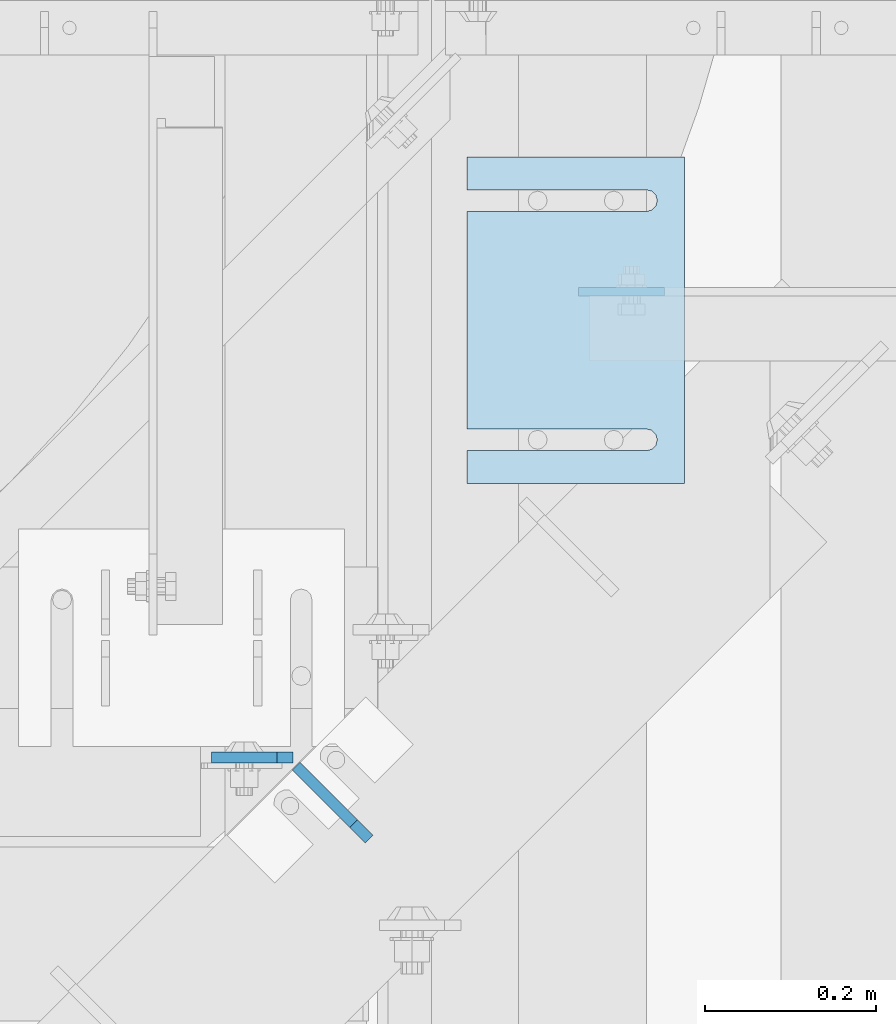
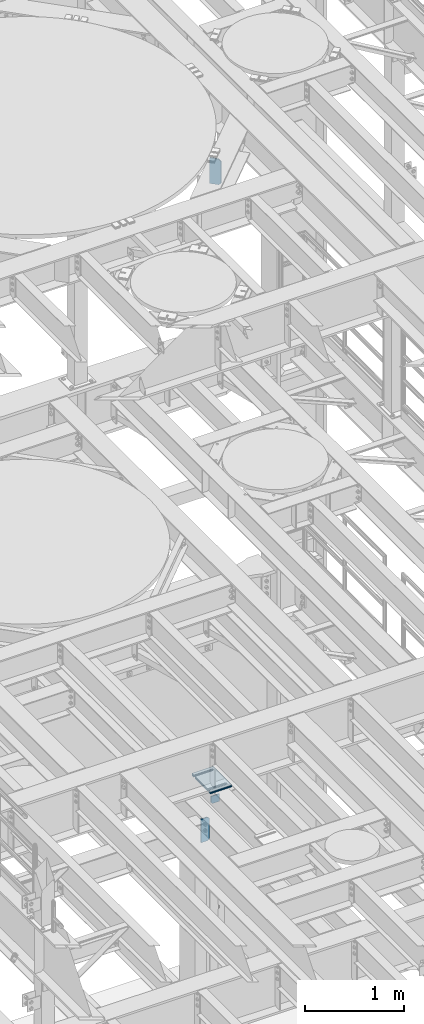
# One storey, part 1785 of 1876: 9 plates, 9 elements without a shape of their own.
"""IFC2X3 building model written with IfcOpenShell, lengths in millimetres."""

from ifc_helpers import new_model, si_unit, frame, origin_with_axes, place, context, subcontext, project, spatial, faceted_brep, material, type_object, element, aggregate, save


model = new_model("IFC2X3")

# Units and contexts
model_context = context("Model", 3, precision=1e-05, world=origin_with_axes())
body_context = subcontext(model_context, "Body", "Model", "MODEL_VIEW")
ifc_project = project(units=[si_unit("LENGTHUNIT", "METRE", prefix="MILLI"), si_unit("AREAUNIT", "SQUARE_METRE"), si_unit("VOLUMEUNIT", "CUBIC_METRE"), si_unit("MASSUNIT", "GRAM", prefix="KILO"), si_unit("TIMEUNIT", "SECOND"), si_unit("PLANEANGLEUNIT", "RADIAN"), si_unit("SOLIDANGLEUNIT", "STERADIAN"), si_unit("THERMODYNAMICTEMPERATUREUNIT", "DEGREE_CELSIUS"), si_unit("LUMINOUSINTENSITYUNIT", "LUMEN")], contexts=[model_context])

# Site, building, storey
site_placement = place(None, origin_with_axes())
site = spatial("IfcSite", under=ifc_project, at=site_placement, CompositionType="ELEMENT")
building_placement = place(site_placement, origin_with_axes())
building = spatial("IfcBuilding", under=site, at=building_placement, Name="Undefined", CompositionType="ELEMENT")
storey_placement = place(building_placement, origin_with_axes())
storey = spatial("IfcBuildingStorey", under=building, at=storey_placement, Name="Undefined", CompositionType="ELEMENT", Elevation=0.0)

# Assembly, plate
assembly_1_placement = place(storey_placement, origin_with_axes())
assembly_1 = element("IfcElementAssembly", 1, at=assembly_1_placement, inside=storey, Name="BEAM", AssemblyPlace="NOTDEFINED", PredefinedType="RIGID_FRAME")
ifc_material = material(Name="STEEL/A36")
plate_type_1 = type_object("IfcPlateType", PredefinedType="NOTDEFINED")
plate_1_placement = place(assembly_1_placement, frame((4883.15000015277, 10669.2456848175, 4921.97603368487), z_axis=(1.0, 0.0, 0.0), x_axis=(0.0, 0.0, -1.0)))
plate_1 = element("IfcPlate", 2, at=plate_1_placement, type_object=plate_type_1, material=ifc_material, Name="PLATE", context=body_context, shape_type="Brep", body=[
    faceted_brep([(0.0, -4.76249999999982, 0.0), (0.0, -4.76250000000073, 100.270820617676), (0.0, 4.76250000000073, 100.270820617676), (0.0, 4.76249999999982, 0.0), (92.8010330200195, -4.76250000000073, 100.270820617676), (92.8010330200195, 4.76250000000073, 100.270820617676), (92.8010330200195, -4.76250000000073, 19.0499992370605), (92.8010330200195, 4.76250000000073, 19.0499992370605), (73.751033782959, -4.76250000000073, 0.0), (73.751033782959, 4.76250000000073, 0.0)], [[[0, 1, 2, 3]], [[1, 4, 5, 2]], [[4, 6, 7, 5]], [[6, 8, 9, 7]], [[8, 0, 3, 9]], [[5, 7, 9, 3, 2]], [[8, 6, 4, 1, 0]]]),
])
aggregate(assembly_1, [plate_1])

assembly_2_placement = place(storey_placement, origin_with_axes())
assembly_2 = element("IfcElementAssembly", 3, at=assembly_2_placement, inside=storey, Name="BEAM", AssemblyPlace="NOTDEFINED", PredefinedType="RIGID_FRAME")
plate_type_2 = type_object("IfcPlateType", PredefinedType="NOTDEFINED")
plate_2_placement = place(assembly_2_placement, frame((4549.775, 10125.0750000954, 4829.175), z_axis=(0.0, 0.0, 1.0), x_axis=(-1.0, 0.0, 0.0)))
plate_2 = element("IfcPlate", 4, at=plate_2_placement, type_object=plate_type_2, material=ifc_material, Name="PLATE", context=body_context, shape_type="Brep", body=[
    faceted_brep([(0.0, -6.35000000000196, 19.0499992370605), (0.0, -6.35000000000036, 271.462512969971), (0.0, 6.35000000000036, 271.462512969971), (0.0, 6.35000000000105, 19.0499992370605), (19.0499992370605, -6.35000000000036, 290.512512207031), (19.0499992370605, 6.35000000000036, 290.512512207031), (95.25, -6.35000000000036, 290.512512207031), (95.25, 6.35000000000036, 290.512512207031), (95.25, -6.35000000000036, 0.0), (95.25, 6.35000000000036, 0.0), (19.0499992370642, -6.35000000000105, 0.0), (19.0499992370633, 6.35000000000105, 0.0)], [[[0, 1, 2, 3]], [[1, 4, 5, 2]], [[4, 6, 7, 5]], [[6, 8, 9, 7]], [[8, 10, 11, 9]], [[10, 0, 3, 11]], [[5, 7, 9, 11, 3, 2]], [[10, 8, 6, 4, 1, 0]]]),
])
aggregate(assembly_2, [plate_2])

assembly_3_placement = place(storey_placement, origin_with_axes())
assembly_3 = element("IfcElementAssembly", 5, at=assembly_3_placement, inside=storey, Name="SHIM PLATE", AssemblyPlace="NOTDEFINED", PredefinedType="RIGID_FRAME")
plate_type_3 = type_object("IfcPlateType", PredefinedType="NOTDEFINED")
plate_3_placement = place(assembly_3_placement, frame((5006.97497870781, 10826.4112121733, 5154.6115), z_axis=(0.0, -1.0, 0.0), x_axis=(-1.0, 0.0, 0.0)))
plate_3 = element("IfcPlate", 6, at=plate_3_placement, type_object=plate_type_3, material=ifc_material, Name="SHIM PLATE", context=body_context, shape_type="Brep", body=[
    faceted_brep([(253.999554443153, -1.58749999999964, 38.1033648203102), (253.999554443153, 1.58749999999964, 38.1033648203102), (44.4515180349081, 1.58749999999964, 38.1033599194243), (44.4515180349081, -1.58749999999964, 38.1033599194243), (38.1012989900955, 1.58749999999964, 39.8049650059338), (38.1012989900955, -1.58749999999964, 39.8049650059338), (33.4527432566947, 1.58749999999964, 44.4538004924843), (33.4527432566947, -1.58749999999964, 44.4538004924843), (31.7515203221346, 1.58749999999964, 50.8041219264323), (31.7515203221346, -1.58749999999964, 50.8041219264323), (33.4535054350827, 1.58749999999964, 57.1542391271496), (33.4535054350827, -1.58749999999964, 57.1542391271496), (38.102619106583, 1.58749999999964, 61.8025166422085), (38.102619106583, -1.58749999999964, 61.8025166422085), (44.4530423390142, 1.58749999999964, 63.5033595381092), (44.4530423390142, -1.58749999999964, 63.5033595381092), (253.999552185923, -1.58749999999964, 63.5033587167945), (253.999552408692, 1.58749999999964, 63.5033587167945), (253.999542236328, -1.58750000000146, 6.16182660451159e-11), (9.09494701772928e-13, -1.58750000000146, 4.54747350886464e-13), (9.09494701772928e-13, 1.58750000000146, 4.54747350886464e-13), (253.999542236328, 1.58750000000146, 6.16182660451159e-11), (-1.83084230229724e-05, -1.58749999999964, 381.006103515625), (-1.83084230229724e-05, 1.58749999999964, 381.006103515625), (253.999526977692, -1.58749999999964, 381.006103515754), (253.999526977692, 1.58749999999964, 381.006103515754), (254.003036796345, -1.58749999999964, 342.901806793585), (253.999530029731, 1.58749999999964, 342.901806793307), (44.4530337445867, -1.58749999999964, 342.901796525332), (44.4530337445867, 1.58749999999964, 342.901796525332), (38.1026104900466, -1.58749999999964, 341.200953711996), (38.1026104900466, 1.58749999999964, 341.200953711996), (33.4534967581139, -1.58749999999964, 336.552676257383), (33.4534967581139, 1.58749999999964, 336.552676257383), (31.7515115626111, -1.58749999999964, 330.202559078798), (31.7515115626111, 1.58749999999964, 330.202559078798), (33.4527344146145, -1.58749999999964, 323.852237622745), (33.4527344146145, 1.58749999999964, 323.852237622745), (38.1012900875803, -1.58749999999964, 319.203402075782), (38.1012900875803, 1.58749999999964, 319.203402075782), (44.4515091102685, -1.58749999999964, 317.501796906747), (44.4515091102685, 1.58749999999964, 317.501796906747), (253.999532064192, -1.58749999999964, 317.501812896822), (253.999532064192, 1.58749999999964, 317.501812896822)], [[[0, 1, 2, 3]], [[3, 2, 4, 5]], [[5, 4, 6, 7]], [[7, 6, 8, 9]], [[9, 8, 10, 11]], [[11, 10, 12, 13]], [[13, 12, 14, 15]], [[16, 15, 14, 17]], [[18, 19, 20, 21]], [[19, 22, 23, 20]], [[22, 24, 25, 23]], [[25, 24, 26, 27]], [[26, 28, 29, 27]], [[30, 31, 29, 28]], [[32, 33, 31, 30]], [[34, 35, 33, 32]], [[36, 37, 35, 34]], [[38, 39, 37, 36]], [[40, 41, 39, 38]], [[42, 43, 41, 40]], [[43, 42, 16, 17]], [[12, 10, 8, 6, 4, 2, 1, 21, 20, 23, 25, 27, 29, 31, 33, 35, 37, 39, 41, 43, 17, 14]], [[18, 21, 1, 0]], [[42, 40, 38, 36, 34, 32, 30, 28, 26, 24, 22, 19, 18, 0, 3, 5, 7, 9, 11, 13, 15, 16]]]),
])
aggregate(assembly_3, [plate_3])

assembly_4_placement = place(storey_placement, origin_with_axes())
assembly_4 = element("IfcElementAssembly", 7, at=assembly_4_placement, inside=storey, Name="SHIM PLATE", AssemblyPlace="NOTDEFINED", PredefinedType="RIGID_FRAME")
plate_4_placement = place(assembly_4_placement, frame((5006.97497870781, 10826.4112121733, 5151.4365), z_axis=(0.0, -1.0, 0.0), x_axis=(-1.0, 0.0, 0.0)))
plate_4 = element("IfcPlate", 8, at=plate_4_placement, type_object=plate_type_3, material=ifc_material, Name="SHIM PLATE", context=body_context, shape_type="Brep", body=[
    faceted_brep([(253.999554443153, -1.58749999999964, 38.1033648203102), (253.999554443153, 1.58749999999964, 38.1033648203102), (44.4515180349081, 1.58749999999964, 38.1033599194243), (44.4515180349081, -1.58749999999964, 38.1033599194243), (38.1012989900955, 1.58749999999964, 39.8049650059338), (38.1012989900955, -1.58749999999964, 39.8049650059338), (33.4527432566947, 1.58749999999964, 44.4538004924843), (33.4527432566947, -1.58749999999964, 44.4538004924843), (31.7515203221346, 1.58749999999964, 50.8041219264323), (31.7515203221346, -1.58749999999964, 50.8041219264323), (33.4535054350827, 1.58749999999964, 57.1542391271496), (33.4535054350827, -1.58749999999964, 57.1542391271496), (38.102619106583, 1.58749999999964, 61.8025166422085), (38.102619106583, -1.58749999999964, 61.8025166422085), (44.4530423390142, 1.58749999999964, 63.5033595381092), (44.4530423390142, -1.58749999999964, 63.5033595381092), (253.999552185923, -1.58749999999964, 63.5033587167945), (253.999552408692, 1.58749999999964, 63.5033587167945), (253.999542236328, -1.58750000000146, 6.16182660451159e-11), (9.09494701772928e-13, -1.58750000000146, 4.54747350886464e-13), (9.09494701772928e-13, 1.58750000000146, 4.54747350886464e-13), (253.999542236328, 1.58750000000146, 6.16182660451159e-11), (-1.83084230229724e-05, -1.58749999999964, 381.006103515625), (-1.83084230229724e-05, 1.58749999999964, 381.006103515625), (253.999526977692, -1.58749999999964, 381.006103515754), (253.999526977692, 1.58749999999964, 381.006103515754), (254.003036796345, -1.58749999999964, 342.901806793585), (253.999530029731, 1.58749999999964, 342.901806793307), (44.4530337445867, -1.58749999999964, 342.901796525332), (44.4530337445867, 1.58749999999964, 342.901796525332), (38.1026104900466, -1.58749999999964, 341.200953711996), (38.1026104900466, 1.58749999999964, 341.200953711996), (33.4534967581139, -1.58749999999964, 336.552676257383), (33.4534967581139, 1.58749999999964, 336.552676257383), (31.7515115626111, -1.58749999999964, 330.202559078798), (31.7515115626111, 1.58749999999964, 330.202559078798), (33.4527344146145, -1.58749999999964, 323.852237622745), (33.4527344146145, 1.58749999999964, 323.852237622745), (38.1012900875803, -1.58749999999964, 319.203402075782), (38.1012900875803, 1.58749999999964, 319.203402075782), (44.4515091102685, -1.58749999999964, 317.501796906747), (44.4515091102685, 1.58749999999964, 317.501796906747), (253.999532064192, -1.58749999999964, 317.501812896822), (253.999532064192, 1.58749999999964, 317.501812896822)], [[[0, 1, 2, 3]], [[3, 2, 4, 5]], [[5, 4, 6, 7]], [[7, 6, 8, 9]], [[9, 8, 10, 11]], [[11, 10, 12, 13]], [[13, 12, 14, 15]], [[16, 15, 14, 17]], [[18, 19, 20, 21]], [[19, 22, 23, 20]], [[22, 24, 25, 23]], [[25, 24, 26, 27]], [[26, 28, 29, 27]], [[30, 31, 29, 28]], [[32, 33, 31, 30]], [[34, 35, 33, 32]], [[36, 37, 35, 34]], [[38, 39, 37, 36]], [[40, 41, 39, 38]], [[42, 43, 41, 40]], [[43, 42, 16, 17]], [[12, 10, 8, 6, 4, 2, 1, 21, 20, 23, 25, 27, 29, 31, 33, 35, 37, 39, 41, 43, 17, 14]], [[18, 21, 1, 0]], [[42, 40, 38, 36, 34, 32, 30, 28, 26, 24, 22, 19, 18, 0, 3, 5, 7, 9, 11, 13, 15, 16]]]),
])
aggregate(assembly_4, [plate_4])

assembly_5_placement = place(storey_placement, origin_with_axes())
assembly_5 = element("IfcElementAssembly", 9, at=assembly_5_placement, inside=storey, Name="SHIM PLATE", AssemblyPlace="NOTDEFINED", PredefinedType="RIGID_FRAME")
plate_type_4 = type_object("IfcPlateType", PredefinedType="NOTDEFINED")
plate_5_placement = place(assembly_5_placement, frame((5006.97497870781, 10826.4112121733, 5156.9925), z_axis=(0.0, -1.0, 0.0), x_axis=(-1.0, 0.0, 0.0)))
plate_5 = element("IfcPlate", 10, at=plate_5_placement, type_object=plate_type_4, material=ifc_material, Name="SHIM PLATE", context=body_context, shape_type="Brep", body=[
    faceted_brep([(253.999554443153, -0.793499999999767, 38.1033648203102), (253.999554443153, 0.793499999999767, 38.1033648203102), (44.4515180349072, 0.793499999999767, 38.1033599194234), (44.4515180349072, -0.793499999999767, 38.1033599194234), (38.1012989900946, 0.793499999999767, 39.8049650059329), (38.1012989900946, -0.793499999999767, 39.8049650059329), (33.4527432566938, 0.793499999999767, 44.4538004924834), (33.4527432566938, -0.793499999999767, 44.4538004924834), (31.7515203221337, 0.793499999999767, 50.8041219264314), (31.7515203221337, -0.793499999999767, 50.8041219264314), (33.4535054350818, 0.793499999999767, 57.1542391271487), (33.4535054350818, -0.793499999999767, 57.1542391271487), (38.1026191065821, 0.793499999999767, 61.8025166422076), (38.1026191065821, -0.793499999999767, 61.8025166422076), (44.4530423390133, 0.793499999999767, 63.5033595381083), (44.4530423390133, -0.793499999999767, 63.5033595381083), (253.999552185923, -0.793499999999767, 63.5033587167945), (253.999552408692, 0.793499999999767, 63.5033587167945), (253.999542236328, -0.793499999999767, 6.16182660451159e-11), (9.09494701772928e-13, -0.793499999999767, 0.0), (9.09494701772928e-13, 0.793499999999767, 0.0), (253.999542236328, 0.793499999999767, 6.16182660451159e-11), (-1.83080774149857e-05, -0.793499999999767, 381.006103515625), (-1.83080774149857e-05, 0.793499999999767, 381.006103515625), (253.999526977692, -0.793499999999767, 381.006103515754), (253.999526977692, 0.793499999999767, 381.006103515754), (254.003036796345, -0.793499999999767, 342.901806793585), (253.999530029731, 0.793499999999767, 342.901806793307), (44.4530337445867, -0.793499999999767, 342.901796525332), (44.4530337445867, 0.793499999999767, 342.901796525332), (38.1026104900466, -0.793499999999767, 341.200953711996), (38.1026104900466, 0.793499999999767, 341.200953711996), (33.4534967581139, -0.793499999999767, 336.552676257383), (33.4534967581139, 0.793499999999767, 336.552676257383), (31.7515115626111, -0.793499999999767, 330.202559078798), (31.7515115626111, 0.793499999999767, 330.202559078798), (33.4527344146145, -0.793499999999767, 323.852237622745), (33.4527344146145, 0.793499999999767, 323.852237622745), (38.1012900875803, -0.793499999999767, 319.203402075782), (38.1012900875803, 0.793499999999767, 319.203402075782), (44.4515091102685, -0.793499999999767, 317.501796906747), (44.4515091102685, 0.793499999999767, 317.501796906747), (253.999532064192, -0.793499999999767, 317.501812896822), (253.999532064192, 0.793499999999767, 317.501812896822)], [[[0, 1, 2, 3]], [[3, 2, 4, 5]], [[5, 4, 6, 7]], [[7, 6, 8, 9]], [[9, 8, 10, 11]], [[11, 10, 12, 13]], [[13, 12, 14, 15]], [[16, 15, 14, 17]], [[18, 19, 20, 21]], [[19, 22, 23, 20]], [[22, 24, 25, 23]], [[25, 24, 26, 27]], [[26, 28, 29, 27]], [[30, 31, 29, 28]], [[32, 33, 31, 30]], [[34, 35, 33, 32]], [[36, 37, 35, 34]], [[38, 39, 37, 36]], [[40, 41, 39, 38]], [[42, 43, 41, 40]], [[43, 42, 16, 17]], [[12, 10, 8, 6, 4, 2, 1, 21, 20, 23, 25, 27, 29, 31, 33, 35, 37, 39, 41, 43, 17, 14]], [[18, 21, 1, 0]], [[42, 40, 38, 36, 34, 32, 30, 28, 26, 24, 22, 19, 18, 0, 3, 5, 7, 9, 11, 13, 15, 16]]]),
])
aggregate(assembly_5, [plate_5])

assembly_6_placement = place(storey_placement, origin_with_axes())
assembly_6 = element("IfcElementAssembly", 11, at=assembly_6_placement, inside=storey, Name="SHIM PLATE", AssemblyPlace="NOTDEFINED", PredefinedType="RIGID_FRAME")
plate_type_5 = type_object("IfcPlateType", PredefinedType="NOTDEFINED")
plate_6_placement = place(assembly_6_placement, frame((5006.97497870781, 10826.4112121733, 5147.468), z_axis=(0.0, -1.0, 0.0), x_axis=(-1.0, 0.0, 0.0)))
plate_6 = element("IfcPlate", 12, at=plate_6_placement, type_object=plate_type_5, material=ifc_material, Name="SHIM PLATE", context=body_context, shape_type="Brep", body=[
    faceted_brep([(253.999554443153, -2.38100000000031, 38.1033648203102), (253.999554443153, 2.38100000000031, 38.1033648203102), (44.4515180349081, 2.38100000000031, 38.1033599194243), (44.4515180349081, -2.38100000000031, 38.1033599194243), (38.1012989900955, 2.38100000000031, 39.8049650059338), (38.1012989900955, -2.38100000000031, 39.8049650059338), (33.4527432566947, 2.38100000000031, 44.4538004924843), (33.4527432566947, -2.38100000000031, 44.4538004924843), (31.7515203221346, 2.38100000000031, 50.8041219264323), (31.7515203221346, -2.38100000000031, 50.8041219264323), (33.4535054350827, 2.38100000000031, 57.1542391271496), (33.4535054350827, -2.38100000000031, 57.1542391271496), (38.102619106583, 2.38100000000031, 61.8025166422085), (38.102619106583, -2.38100000000031, 61.8025166422085), (44.4530423390142, 2.38100000000031, 63.5033595381092), (44.4530423390142, -2.38100000000031, 63.5033595381092), (253.999552185923, -2.38100000000031, 63.5033587167945), (253.999552408692, 2.38100000000031, 63.5033587167945), (253.999542236328, -2.38100000000122, 6.16182660451159e-11), (0.0, -2.38100000000122, 4.54747350886464e-13), (0.0, 2.38100000000122, 4.54747350886464e-13), (253.999542236328, 2.38100000000122, 6.16182660451159e-11), (-1.83087686309591e-05, -2.38100000000031, 381.006103515625), (-1.83087686309591e-05, 2.38100000000031, 381.006103515625), (253.999526977692, -2.38100000000031, 381.006103515754), (253.999526977692, 2.38100000000031, 381.006103515754), (254.003036796345, -2.38100000000031, 342.901806793585), (253.999530029731, 2.38100000000031, 342.901806793307), (44.4530337445867, -2.38100000000031, 342.901796525332), (44.4530337445867, 2.38100000000031, 342.901796525332), (38.1026104900466, -2.38100000000031, 341.200953711996), (38.1026104900466, 2.38100000000031, 341.200953711996), (33.4534967581139, -2.38100000000031, 336.552676257383), (33.4534967581139, 2.38100000000031, 336.552676257383), (31.7515115626111, -2.38100000000031, 330.202559078798), (31.7515115626111, 2.38100000000031, 330.202559078798), (33.4527344146145, -2.38100000000031, 323.852237622745), (33.4527344146145, 2.38100000000031, 323.852237622745), (38.1012900875803, -2.38100000000031, 319.203402075782), (38.1012900875803, 2.38100000000031, 319.203402075782), (44.4515091102685, -2.38100000000031, 317.501796906747), (44.4515091102685, 2.38100000000031, 317.501796906747), (253.999532064192, -2.38100000000031, 317.501812896822), (253.999532064192, 2.38100000000031, 317.501812896822)], [[[0, 1, 2, 3]], [[3, 2, 4, 5]], [[5, 4, 6, 7]], [[7, 6, 8, 9]], [[9, 8, 10, 11]], [[11, 10, 12, 13]], [[13, 12, 14, 15]], [[16, 15, 14, 17]], [[18, 19, 20, 21]], [[19, 22, 23, 20]], [[22, 24, 25, 23]], [[25, 24, 26, 27]], [[26, 28, 29, 27]], [[30, 31, 29, 28]], [[32, 33, 31, 30]], [[34, 35, 33, 32]], [[36, 37, 35, 34]], [[38, 39, 37, 36]], [[40, 41, 39, 38]], [[42, 43, 41, 40]], [[43, 42, 16, 17]], [[12, 10, 8, 6, 4, 2, 1, 21, 20, 23, 25, 27, 29, 31, 33, 35, 37, 39, 41, 43, 17, 14]], [[18, 21, 1, 0]], [[42, 40, 38, 36, 34, 32, 30, 28, 26, 24, 22, 19, 18, 0, 3, 5, 7, 9, 11, 13, 15, 16]]]),
])
aggregate(assembly_6, [plate_6])

assembly_7_placement = place(storey_placement, origin_with_axes())
assembly_7 = element("IfcElementAssembly", 13, at=assembly_7_placement, inside=storey, Name="SHIM PLATE", AssemblyPlace="NOTDEFINED", PredefinedType="RIGID_FRAME")
plate_7_placement = place(assembly_7_placement, frame((5006.97497870781, 10826.4112121733, 5142.706), z_axis=(0.0, -1.0, 0.0), x_axis=(-1.0, 0.0, 0.0)))
plate_7 = element("IfcPlate", 14, at=plate_7_placement, type_object=plate_type_5, material=ifc_material, Name="SHIM PLATE", context=body_context, shape_type="Brep", body=[
    faceted_brep([(253.999554443153, -2.38100000000031, 38.1033648203102), (253.999554443153, 2.38100000000031, 38.1033648203102), (44.4515180349081, 2.38100000000031, 38.1033599194243), (44.4515180349081, -2.38100000000031, 38.1033599194243), (38.1012989900955, 2.38100000000031, 39.8049650059338), (38.1012989900955, -2.38100000000031, 39.8049650059338), (33.4527432566947, 2.38100000000031, 44.4538004924843), (33.4527432566947, -2.38100000000031, 44.4538004924843), (31.7515203221346, 2.38100000000031, 50.8041219264323), (31.7515203221346, -2.38100000000031, 50.8041219264323), (33.4535054350827, 2.38100000000031, 57.1542391271496), (33.4535054350827, -2.38100000000031, 57.1542391271496), (38.102619106583, 2.38100000000031, 61.8025166422085), (38.102619106583, -2.38100000000031, 61.8025166422085), (44.4530423390142, 2.38100000000031, 63.5033595381092), (44.4530423390142, -2.38100000000031, 63.5033595381092), (253.999552185923, -2.38100000000031, 63.5033587167945), (253.999552408692, 2.38100000000031, 63.5033587167945), (253.999542236328, -2.38100000000122, 6.16182660451159e-11), (0.0, -2.38100000000122, 4.54747350886464e-13), (0.0, 2.38100000000122, 4.54747350886464e-13), (253.999542236328, 2.38100000000122, 6.16182660451159e-11), (-1.83087686309591e-05, -2.38100000000031, 381.006103515625), (-1.83087686309591e-05, 2.38100000000031, 381.006103515625), (253.999526977692, -2.38100000000031, 381.006103515754), (253.999526977692, 2.38100000000031, 381.006103515754), (254.003036796345, -2.38100000000031, 342.901806793585), (253.999530029731, 2.38100000000031, 342.901806793307), (44.4530337445867, -2.38100000000031, 342.901796525332), (44.4530337445867, 2.38100000000031, 342.901796525332), (38.1026104900466, -2.38100000000031, 341.200953711996), (38.1026104900466, 2.38100000000031, 341.200953711996), (33.4534967581139, -2.38100000000031, 336.552676257383), (33.4534967581139, 2.38100000000031, 336.552676257383), (31.7515115626111, -2.38100000000031, 330.202559078798), (31.7515115626111, 2.38100000000031, 330.202559078798), (33.4527344146145, -2.38100000000031, 323.852237622745), (33.4527344146145, 2.38100000000031, 323.852237622745), (38.1012900875803, -2.38100000000031, 319.203402075782), (38.1012900875803, 2.38100000000031, 319.203402075782), (44.4515091102685, -2.38100000000031, 317.501796906747), (44.4515091102685, 2.38100000000031, 317.501796906747), (253.999532064192, -2.38100000000031, 317.501812896822), (253.999532064192, 2.38100000000031, 317.501812896822)], [[[0, 1, 2, 3]], [[3, 2, 4, 5]], [[5, 4, 6, 7]], [[7, 6, 8, 9]], [[9, 8, 10, 11]], [[11, 10, 12, 13]], [[13, 12, 14, 15]], [[16, 15, 14, 17]], [[18, 19, 20, 21]], [[19, 22, 23, 20]], [[22, 24, 25, 23]], [[25, 24, 26, 27]], [[26, 28, 29, 27]], [[30, 31, 29, 28]], [[32, 33, 31, 30]], [[34, 35, 33, 32]], [[36, 37, 35, 34]], [[38, 39, 37, 36]], [[40, 41, 39, 38]], [[42, 43, 41, 40]], [[43, 42, 16, 17]], [[12, 10, 8, 6, 4, 2, 1, 21, 20, 23, 25, 27, 29, 31, 33, 35, 37, 39, 41, 43, 17, 14]], [[18, 21, 1, 0]], [[42, 40, 38, 36, 34, 32, 30, 28, 26, 24, 22, 19, 18, 0, 3, 5, 7, 9, 11, 13, 15, 16]]]),
])
aggregate(assembly_7, [plate_7])

assembly_8_placement = place(storey_placement, origin_with_axes())
assembly_8 = element("IfcElementAssembly", 15, at=assembly_8_placement, inside=storey, Name="SHIM PLATE", AssemblyPlace="NOTDEFINED", PredefinedType="RIGID_FRAME")
plate_type_6 = type_object("IfcPlateType", PredefinedType="NOTDEFINED")
plate_8_placement = place(assembly_8_placement, frame((5006.97497870781, 10826.4112121733, 5135.5625), z_axis=(0.0, -1.0, 0.0), x_axis=(-1.0, 0.0, 0.0)))
plate_8 = element("IfcPlate", 16, at=plate_8_placement, type_object=plate_type_6, material=ifc_material, Name="SHIM PLATE", context=body_context, shape_type="Brep", body=[
    faceted_brep([(253.999554443153, -4.76249999999982, 38.1033648203102), (253.999554443153, 4.76249999999982, 38.1033648203102), (44.4515180349081, 4.76249999999982, 38.1033599194243), (44.4515180349081, -4.76249999999982, 38.1033599194243), (38.1012989900955, 4.76249999999982, 39.8049650059338), (38.1012989900955, -4.76249999999982, 39.8049650059338), (33.4527432566947, 4.76249999999982, 44.4538004924843), (33.4527432566947, -4.76249999999982, 44.4538004924843), (31.7515203221346, 4.76249999999982, 50.8041219264323), (31.7515203221346, -4.76249999999982, 50.8041219264323), (33.4535054350827, 4.76249999999982, 57.1542391271496), (33.4535054350827, -4.76249999999982, 57.1542391271496), (38.102619106583, 4.76249999999982, 61.8025166422085), (38.102619106583, -4.76249999999982, 61.8025166422085), (44.4530423390142, 4.76249999999982, 63.5033595381092), (44.4530423390142, -4.76249999999982, 63.5033595381092), (253.999552185923, -4.76249999999982, 63.5033587167945), (253.999552408692, 4.76249999999982, 63.5033587167945), (253.999542236328, -4.76250000000073, 6.16182660451159e-11), (0.0, -4.76249999999982, 0.0), (0.0, 4.76249999999982, 0.0), (253.999542236328, 4.76250000000073, 6.16182660451159e-11), (-1.83091142389458e-05, -4.76249999999982, 381.006103515625), (-1.83091142389458e-05, 4.76249999999982, 381.006103515625), (253.999526977692, -4.76249999999982, 381.006103515754), (253.999526977692, 4.76249999999982, 381.006103515754), (254.003036796345, -4.76249999999982, 342.901806793585), (253.999530029731, 4.76249999999982, 342.901806793307), (44.4530337445867, -4.76249999999982, 342.901796525332), (44.4530337445867, 4.76249999999982, 342.901796525332), (38.1026104900466, -4.76249999999982, 341.200953711996), (38.1026104900466, 4.76249999999982, 341.200953711996), (33.4534967581139, -4.76249999999982, 336.552676257383), (33.4534967581139, 4.76249999999982, 336.552676257383), (31.7515115626111, -4.76249999999982, 330.202559078798), (31.7515115626111, 4.76249999999982, 330.202559078798), (33.4527344146145, -4.76249999999982, 323.852237622745), (33.4527344146145, 4.76249999999982, 323.852237622745), (38.1012900875803, -4.76249999999982, 319.203402075782), (38.1012900875803, 4.76249999999982, 319.203402075782), (44.4515091102685, -4.76249999999982, 317.501796906747), (44.4515091102685, 4.76249999999982, 317.501796906747), (253.999532064192, -4.76249999999982, 317.501812896822), (253.999532064192, 4.76249999999982, 317.501812896822)], [[[0, 1, 2, 3]], [[3, 2, 4, 5]], [[5, 4, 6, 7]], [[7, 6, 8, 9]], [[9, 8, 10, 11]], [[11, 10, 12, 13]], [[13, 12, 14, 15]], [[16, 15, 14, 17]], [[18, 19, 20, 21]], [[19, 22, 23, 20]], [[22, 24, 25, 23]], [[25, 24, 26, 27]], [[26, 28, 29, 27]], [[30, 31, 29, 28]], [[32, 33, 31, 30]], [[34, 35, 33, 32]], [[36, 37, 35, 34]], [[38, 39, 37, 36]], [[40, 41, 39, 38]], [[42, 43, 41, 40]], [[43, 42, 16, 17]], [[12, 10, 8, 6, 4, 2, 1, 21, 20, 23, 25, 27, 29, 31, 33, 35, 37, 39, 41, 43, 17, 14]], [[18, 21, 1, 0]], [[42, 40, 38, 36, 34, 32, 30, 28, 26, 24, 22, 19, 18, 0, 3, 5, 7, 9, 11, 13, 15, 16]]]),
])
aggregate(assembly_8, [plate_8])

assembly_9_placement = place(storey_placement, origin_with_axes())
assembly_9 = element("IfcElementAssembly", 17, at=assembly_9_placement, inside=storey, Name="BEAM", AssemblyPlace="NOTDEFINED", PredefinedType="RIGID_FRAME")
plate_type_7 = type_object("IfcPlateType", PredefinedType="NOTDEFINED")
plate_9_placement = place(assembly_9_placement, frame((4638.66687390065, 10029.8305620778, 12973.0499999816), z_axis=(0.0, 0.0, 1.0), x_axis=(-0.707106781186548, 0.707106781186547, 0.0)))
plate_9 = element("IfcPlate", 18, at=plate_9_placement, type_object=plate_type_7, material=ifc_material, Name="PLATE", context=body_context, shape_type="Brep", body=[
    faceted_brep([(0.0, -6.35000000000036, 25.4000000000005), (-1.13686837721616e-12, -6.35000000000082, 292.100006103516), (1.13686837721616e-12, 6.35000000000105, 292.100006103516), (0.0, 6.35000000000036, 25.4000000000005), (25.3999996185303, -6.34999999999991, 317.5), (25.3999996185303, 6.34999999999991, 317.5), (120.650001525899, -6.35000000000309, 317.5), (120.650001525897, 6.34999999999764, 317.5), (120.650001525899, -6.35000000000309, -1.81898940354586e-12), (120.650001525897, 6.34999999999764, -1.81898940354586e-12), (25.3999996185303, -6.34999999999991, 0.0), (25.3999996185303, 6.34999999999991, 0.0)], [[[0, 1, 2, 3]], [[1, 4, 5, 2]], [[4, 6, 7, 5]], [[6, 8, 9, 7]], [[8, 10, 11, 9]], [[10, 0, 3, 11]], [[5, 7, 9, 11, 3, 2]], [[10, 8, 6, 4, 1, 0]]]),
])
aggregate(assembly_9, [plate_9])

save(model, "model.ifc")
